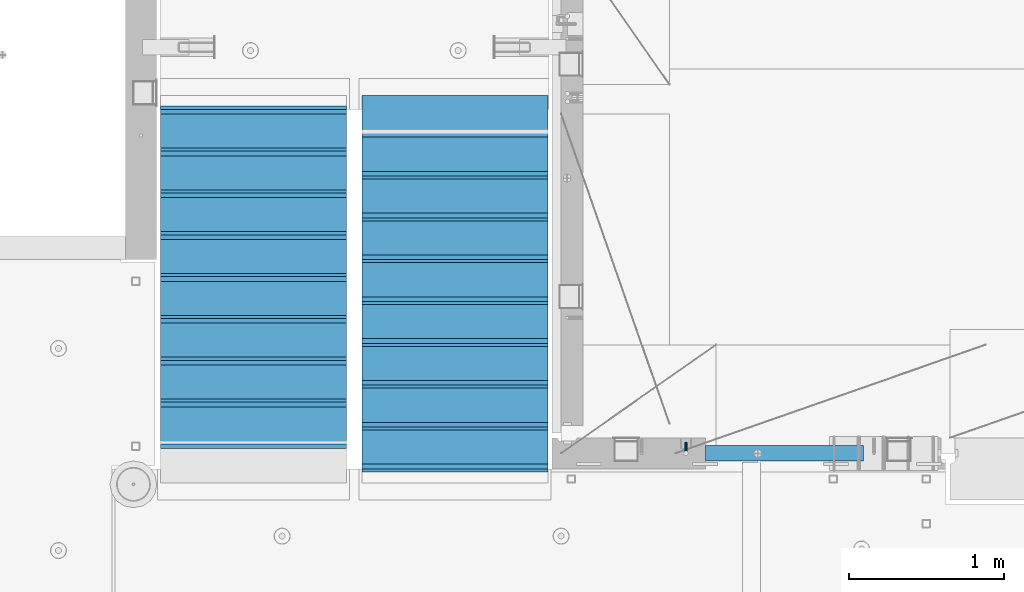
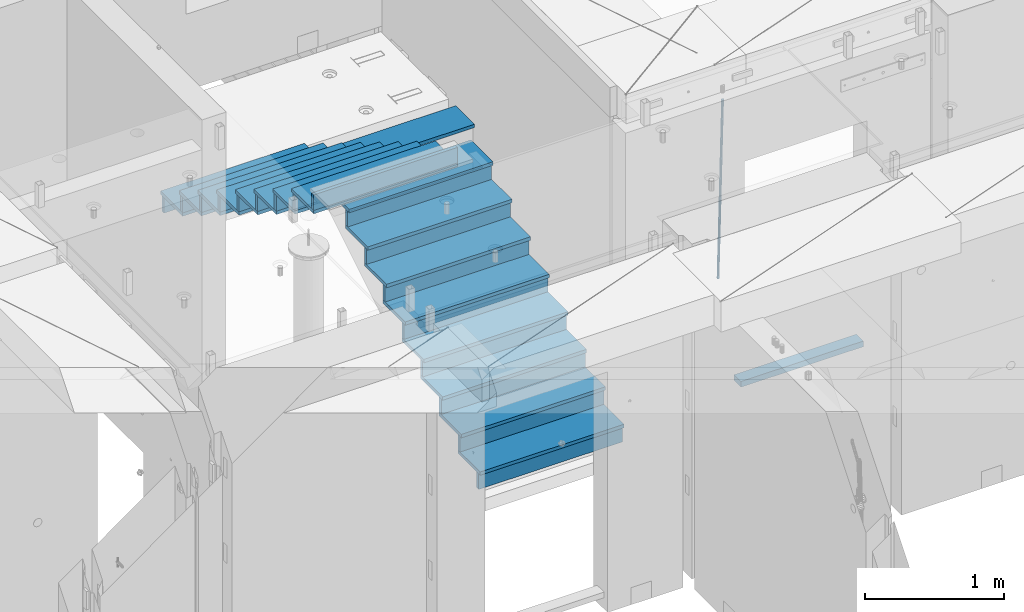
# One storey, part 119 of 349: 36 beams, 3 elements without a shape of their own.
"""IFC2X3 building model written with IfcOpenShell, lengths in millimetres."""

from ifc_helpers import new_model, si_unit, frame, origin_with_axes, place, context, subcontext, project, spatial, faceted_brep, material, type_object, element, aggregate, save


model = new_model("IFC2X3")

# Units and contexts
model_context = context("Model", 3, precision=1e-05, world=origin_with_axes())
body_context = subcontext(model_context, "Body", "Model", "MODEL_VIEW")
ifc_project = project(units=[si_unit("LENGTHUNIT", "METRE", prefix="MILLI"), si_unit("AREAUNIT", "SQUARE_METRE"), si_unit("VOLUMEUNIT", "CUBIC_METRE"), si_unit("MASSUNIT", "GRAM", prefix="KILO"), si_unit("TIMEUNIT", "SECOND"), si_unit("PLANEANGLEUNIT", "RADIAN"), si_unit("SOLIDANGLEUNIT", "STERADIAN"), si_unit("THERMODYNAMICTEMPERATUREUNIT", "DEGREE_CELSIUS"), si_unit("LUMINOUSINTENSITYUNIT", "LUMEN")], contexts=[model_context])

# Site, building, storey
site_placement = place(None, origin_with_axes())
site = spatial("IfcSite", under=ifc_project, at=site_placement, CompositionType="ELEMENT")
building_placement = place(site_placement, origin_with_axes())
building = spatial("IfcBuilding", under=site, at=building_placement, CompositionType="ELEMENT")
storey_placement = place(building_placement, origin_with_axes())
storey = spatial("IfcBuildingStorey", under=building, at=storey_placement, Name="4", CompositionType="ELEMENT", Elevation=0.0)

# Assembly, beams
assembly_1_placement = place(storey_placement, origin_with_axes())
assembly_1 = element("IfcElementAssembly", 1, at=assembly_1_placement, inside=storey, AssemblyPlace="NOTDEFINED", PredefinedType="REINFORCEMENT_UNIT")
ifc_material_1 = material()
beam_type_1 = type_object("IfcBeamType", Name="D20", PredefinedType="NOTDEFINED")
beam_1_placement = place(assembly_1_placement, frame((23075.0006866416, 17045.0000022791, 91790.0), z_axis=(0.00020576299992186, -0.999642804629538, -0.0267249099901004), x_axis=(-4.30000201928125e-08, -0.0267249099948059, 0.999642825806181)))
beam_1 = element("IfcBeam", 2, at=beam_1_placement, type_object=beam_type_1, material=ifc_material_1, Name="JM20", ObjectType="D20", context=body_context, shape_type="Brep", body=[
    faceted_brep([(0.0, -10.0, 0.0), (-4.19531716033816e-08, -7.07106781186667, -7.07106781187031), (60.4266690400545, -7.0710677960451, -7.07106780570757), (60.4266690441291, -9.99999998418934, 6.15546014159918e-09), (0.0, 0.0, -10.0), (60.426669036824, 1.58106558956206e-08, -9.99999999384454), (4.196772351861e-08, 7.07106781186303, -7.07106781186667), (60.4266690363438, 7.07106782768096, -7.07106780570757), (0.0, 10.0, 0.0), (60.4266690388904, 10.0000000158179, 6.15182216279209e-09), (4.196772351861e-08, 7.07106781185939, 7.07106781185939), (60.4266690429649, 7.07106782768096, 7.07106781802577), (0.0, 0.0, 10.0), (60.4266690461809, 1.58179318532348e-08, 10.0000000061555), (-4.19531716033816e-08, -7.07106781187031, 7.07106781185939), (60.4266690466611, -7.07106779605238, 7.07106781802213), (61.0378400410118, -7.07106779588503, -7.07106780564936), (60.991799419251, -9.99999998403655, 6.21366780251265e-09), (61.0569027789461, 1.5985278878361e-08, -9.99999999378269), (61.0378209396877, 7.07106782784831, -7.07106780564936), (60.9917724058905, 10.0000000159635, 6.21366780251265e-09), (60.9457317841297, 7.07106782781193, 7.0710678180767), (60.9266690461809, 1.59488990902901e-08, 10.0000000062028), (60.9457508854539, -7.07106779591413, 7.0710678180767), (61.6489592143771, -7.07106614513759, -7.06310863441468), (61.5568818710308, -9.9999984576425, 0.00735959856683621), (61.6870830769039, 1.71821739058942e-06, -9.99179257185824), (61.6489210170112, 7.07106947854481, -7.06310888312146), (61.556827851804, 10.0000015422847, 0.00735924683976918), (61.4647505084577, 7.07106922979438, 7.07782747982128), (61.4266266459163, 1.36643211590126e-06, 10.0065114172685), (61.464788705809, -7.07106639389531, 7.07782772852806), (176.543135720174, -7.07075579406956, -5.56673531796696), (176.451058376813, -9.99968810657447, 1.50373291501455), (176.581259582701, 0.000312069292704109, -8.49541925541052), (176.543097522794, 7.07137982961285, -5.56673556667374), (176.451004357587, 10.00031189336, 1.50373256329476), (176.35892701424, 7.07137958085514, 8.57420079627263), (176.320803151699, 0.000311717507429421, 11.5028847337162), (176.358965211621, -7.07075604281999, 8.57420104497578), (177.098753836006, -7.07075429323595, -5.55949898843028), (176.98362511232, -9.99968666800123, 1.510669025065), (177.146421932586, 0.000313595905026887, -8.48805862247536), (177.098706077581, 7.07138133041735, -5.55949936166144), (176.983557571715, 10.0003133318824, 1.51066849724157), (176.868428848029, 7.07138095712435, 8.58083651073321), (176.820760751449, 0.000313067976094317, 11.5093961447819), (176.868476606425, -7.07075466652896, 8.58083688396073), (177.654312950661, -7.07075204110879, -5.54863964998367), (177.516135294456, -9.99968450931192, 1.52107783331303), (177.711524267797, 0.000315886711177882, -8.47701274570863), (177.654255632195, 7.07138358250813, -5.54864021007961), (177.516054233929, 10.0003154905207, 1.5210770412159), (177.377876577739, 7.0713830223176, 8.59079452451624), (177.320665260588, 0.000315094497636892, 11.5191676202448), (177.377933896176, -7.07075260129932, 8.59079508461218), (299.580241614967, -7.07025777803938, -3.16539205229128), (299.442063958748, -9.99919024624614, 3.90432543100542), (299.637452932104, 0.000810149780591019, -6.09376514801625), (299.58018429653, 7.07187784557391, -3.16539261238358), (299.441982898265, 10.0008097535901, 3.90432463891557), (299.303805242045, 7.07187728538338, 10.974042122205), (299.246593924894, 0.00080935756341205, 13.9024152179336), (299.303862560482, -7.07025833822991, 10.9740426822973), (300.088882651282, -7.07025571611666, -3.15544980669438), (299.971788958996, -9.99918809853989, 3.91467979818117), (300.137357441272, 0.000812176291219657, -6.0839936725497), (300.088834180511, 7.07187990754028, -3.15545019384081), (299.971753863239, 10.0008119014747, 3.91467990454839), (299.854660170953, 7.07187951844026, 10.9848095094276), (299.806185380992, 0.000811626032373169, 13.9133533752902), (299.854708641738, -7.07025610520941, 10.9848098965813), (300.597573977022, -7.07025429077839, -3.14854421417112), (300.501599787152, -9.99918661431002, 3.92187219230618), (300.637311376035, 0.00081357714952901, -6.07720669196715), (300.597534354776, 7.07188133290401, -3.14854448120241), (300.501543752835, 10.0008133856099, 3.92187181466215), (300.40556956298, 7.07188106207104, 10.9922882211395), (300.365832163967, 0.000813194146758178, 13.9209506989318), (300.405609185211, -7.07025456160045, 10.9922884881707), (1494.60304651056, -7.06690872122999, 13.060333041718), (1494.50707232069, -9.99584104476162, 20.1307494481916), (1494.64278390956, 0.00415914670156781, 10.1316705639183), (1494.6030068883, 7.07522690244878, 13.0603327746867), (1494.50701628637, 10.004158955162, 20.1307490705476), (1494.4110420965, 7.07522663162308, 27.2011654770249), (1494.3713046975, 0.00415876370243495, 30.1298279548209), (1494.41108171875, -7.06690899205205, 27.2011657440526), (1495.1211563645, -7.06690726950183, 13.067366492749), (1495.00702625545, -9.99583964390331, 20.1375364287742), (1495.20660775043, 0.00416072652296862, 10.1393245920117), (1495.21332415029, 7.07522861253892, 13.0686179608165), (1495.13737118813, 10.0041607213934, 20.1393062718889), (1495.02324107911, 7.07522834699193, 27.2094762079141), (1494.93778969315, 0.00416035097441636, 30.1375181086514), (1494.93107329329, -7.06690753504881, 27.2082247398503), (1495.63922435709, -7.07365070849846, 13.0742491942874), (1495.5069397148, -10.00235861486, 20.1441724282631), (1495.77038591086, -0.00317370150150964, 10.1468279224828), (1495.82359171678, 7.06728286786529, 13.0767522910828), (1495.76767453534, 9.99594143344802, 20.1477123416917), (1495.63538989302, 7.0672335270865, 27.2176355756565), (1495.50422833927, -0.00324347991045215, 30.1450568474684), (1495.45102253335, -7.07370004928453, 27.2151324788683), (1517.48046966468, -7.35846502584536, 13.3649345949125), (1517.34818502239, -10.2871729322142, 20.4348578288809), (1517.61163121845, -0.287988018848409, 10.4375133231042), (1517.66483702436, 6.78246855052203, 13.3674376917079), (1517.60891984291, 9.71112711610476, 20.4383977423167), (1517.47663520063, 6.78241920973232, 27.5083209762815), (1517.34547364687, -0.288057797257352, 30.4357422480862), (1517.29226784095, -7.35851436663143, 27.5058178794898), (1518.11590717161, -7.36675126123009, 13.3733916404526), (1518.00827439407, -10.295780632965, 20.4436429663911), (1518.18994308249, -0.295529324139352, 10.4452100827657), (1518.18701289421, 6.77565927010801, 13.3743873367348), (1518.10883307132, 9.70460814510079, 20.4450510935785), (1518.00120029377, 6.77557877335857, 27.515302419517), (1517.9271643829, -0.295643163732166, 30.4434839772002), (1517.93009457119, -7.36683175797953, 27.5143067232275), (1518.75139849893, -7.36487536471395, 13.3816537936873), (1518.66841952164, -10.2938120781764, 20.4522328350286), (1518.76830418318, -0.293831718903675, 10.452712053142), (1518.7092334538, 6.77719739167878, 13.3811419616068), (1518.60878914295, 9.7060990139762, 20.4515089951637), (1518.52581016565, 6.77716230052101, 27.522088036505), (1518.50890448141, -0.293881345296541, 30.4510297770539), (1518.56797521077, -7.36491045587172, 27.5225998685855), (1618.77218426704, -7.06661321754655, 14.6790318180938), (1618.68920528975, -9.99554993101265, 21.7496108594387), (1618.78908995127, 0.0044304282637313, 11.7500900775485), (1618.73001922191, 7.07545953884255, 14.6785199860096), (1618.62957491104, 10.0043611611436, 21.748887019563), (1618.54659593375, 7.07542444768478, 28.8194660609042), (1618.52969024952, 0.00438080187086598, 31.7484078014531), (1618.58876097888, -7.06664830870795, 28.819977892992)], [[[0, 1, 2, 3]], [[1, 4, 5, 2]], [[4, 6, 7, 5]], [[6, 8, 9, 7]], [[8, 10, 11, 9]], [[10, 12, 13, 11]], [[12, 14, 15, 13]], [[14, 0, 3, 15]], [[14, 12, 10, 8, 6, 4, 1, 0]], [[3, 2, 16, 17]], [[2, 5, 18, 16]], [[5, 7, 19, 18]], [[7, 9, 20, 19]], [[9, 11, 21, 20]], [[11, 13, 22, 21]], [[13, 15, 23, 22]], [[15, 3, 17, 23]], [[17, 16, 24, 25]], [[16, 18, 26, 24]], [[18, 19, 27, 26]], [[19, 20, 28, 27]], [[20, 21, 29, 28]], [[21, 22, 30, 29]], [[22, 23, 31, 30]], [[23, 17, 25, 31]], [[25, 24, 32, 33]], [[24, 26, 34, 32]], [[26, 27, 35, 34]], [[27, 28, 36, 35]], [[28, 29, 37, 36]], [[29, 30, 38, 37]], [[30, 31, 39, 38]], [[31, 25, 33, 39]], [[33, 32, 40, 41]], [[32, 34, 42, 40]], [[34, 35, 43, 42]], [[35, 36, 44, 43]], [[36, 37, 45, 44]], [[37, 38, 46, 45]], [[38, 39, 47, 46]], [[39, 33, 41, 47]], [[41, 40, 48, 49]], [[40, 42, 50, 48]], [[42, 43, 51, 50]], [[43, 44, 52, 51]], [[44, 45, 53, 52]], [[45, 46, 54, 53]], [[46, 47, 55, 54]], [[47, 41, 49, 55]], [[49, 48, 56, 57]], [[48, 50, 58, 56]], [[50, 51, 59, 58]], [[51, 52, 60, 59]], [[52, 53, 61, 60]], [[53, 54, 62, 61]], [[54, 55, 63, 62]], [[55, 49, 57, 63]], [[57, 56, 64, 65]], [[56, 58, 66, 64]], [[58, 59, 67, 66]], [[59, 60, 68, 67]], [[60, 61, 69, 68]], [[61, 62, 70, 69]], [[62, 63, 71, 70]], [[63, 57, 65, 71]], [[65, 64, 72, 73]], [[64, 66, 74, 72]], [[66, 67, 75, 74]], [[67, 68, 76, 75]], [[68, 69, 77, 76]], [[69, 70, 78, 77]], [[70, 71, 79, 78]], [[71, 65, 73, 79]], [[73, 72, 80, 81]], [[72, 74, 82, 80]], [[74, 75, 83, 82]], [[75, 76, 84, 83]], [[76, 77, 85, 84]], [[77, 78, 86, 85]], [[78, 79, 87, 86]], [[79, 73, 81, 87]], [[81, 80, 88, 89]], [[80, 82, 90, 88]], [[82, 83, 91, 90]], [[83, 84, 92, 91]], [[84, 85, 93, 92]], [[85, 86, 94, 93]], [[86, 87, 95, 94]], [[87, 81, 89, 95]], [[89, 88, 96, 97]], [[88, 90, 98, 96]], [[90, 91, 99, 98]], [[91, 92, 100, 99]], [[92, 93, 101, 100]], [[93, 94, 102, 101]], [[94, 95, 103, 102]], [[95, 89, 97, 103]], [[97, 96, 104, 105]], [[96, 98, 106, 104]], [[98, 99, 107, 106]], [[99, 100, 108, 107]], [[100, 101, 109, 108]], [[101, 102, 110, 109]], [[102, 103, 111, 110]], [[103, 97, 105, 111]], [[105, 104, 112, 113]], [[104, 106, 114, 112]], [[106, 107, 115, 114]], [[107, 108, 116, 115]], [[108, 109, 117, 116]], [[109, 110, 118, 117]], [[110, 111, 119, 118]], [[111, 105, 113, 119]], [[113, 112, 120, 121]], [[112, 114, 122, 120]], [[114, 115, 123, 122]], [[115, 116, 124, 123]], [[116, 117, 125, 124]], [[117, 118, 126, 125]], [[118, 119, 127, 126]], [[119, 113, 121, 127]], [[121, 120, 128, 129]], [[120, 122, 130, 128]], [[122, 123, 131, 130]], [[123, 124, 132, 131]], [[124, 125, 133, 132]], [[125, 126, 134, 133]], [[126, 127, 135, 134]], [[127, 121, 129, 135]], [[130, 131, 132, 133, 134, 135, 129, 128]]]),
])
ifc_material_2 = material(Name="TIMBER/T24")
beam_type_2 = type_object("IfcBeamType", PredefinedType="NOTDEFINED")
beam_2_placement = place(assembly_1_placement, frame((23200.0006866455, 16980.0, 90880.0), z_axis=(0.0, 0.0, 1.0), x_axis=(1.0, 0.0, 0.0)))
beam_2 = element("IfcBeam", 3, at=beam_2_placement, type_object=beam_type_2, material=ifc_material_2, context=body_context, shape_type="Brep", body=[
    faceted_brep([(0.0, 50.0, -25.0), (0.0, 50.0, 25.0), (1020.0, 50.0, 25.0), (1020.0, 50.0, -25.0), (0.0, -50.0, 25.0), (1020.0, -50.0, 25.0), (0.0, -50.0, -25.0), (1020.0, -50.0, -25.0)], [[[0, 1, 2, 3]], [[1, 4, 5, 2]], [[4, 6, 7, 5]], [[6, 0, 3, 7]], [[5, 7, 3, 2]], [[6, 4, 1, 0]]]),
])
aggregate(assembly_1, [beam_1, beam_2])

assembly_2_placement = place(storey_placement, origin_with_axes())
assembly_2 = element("IfcElementAssembly", 4, at=assembly_2_placement, inside=storey, Name="E9", AssemblyPlace="NOTDEFINED", PredefinedType="NOTDEFINED")
ifc_material_3 = material(Name="Undefined/C32/40")
beam_type_3 = type_object("IfcBeamType", PredefinedType="NOTDEFINED")
beam_3_placement = place(assembly_2_placement, frame((20885.0002457424, 17024.9998138874, 93662.1), z_axis=(0.0, 1.0, 0.0), x_axis=(-1.0, 3.00000001838171e-08, 0.0)))
beam_3 = element("IfcBeam", 5, at=beam_3_placement, type_object=beam_type_3, material=ifc_material_3, Name="E9", context=body_context, shape_type="Brep", body=[
    faceted_brep([(0.0, 68.5, -15.0), (0.0, 68.5, 15.0), (1200.0, 68.5, 15.0), (1200.0, 68.5, -15.0), (0.0, -68.5, 15.0), (1200.0, -68.5, 15.0), (0.0, -68.5, -15.0), (1200.0, -68.5, -15.0)], [[[0, 1, 2, 3]], [[1, 4, 5, 2]], [[4, 6, 7, 5]], [[6, 0, 3, 7]], [[5, 7, 3, 2]], [[6, 4, 1, 0]]]),
])
beam_4_placement = place(assembly_2_placement, frame((20885.0002457424, 17294.9998138874, 93495.4), z_axis=(0.0, 1.0, 0.0), x_axis=(-1.0, 3.00000001838171e-08, 0.0)))
beam_4 = element("IfcBeam", 6, at=beam_4_placement, type_object=beam_type_3, material=ifc_material_3, Name="E9", context=body_context, shape_type="Brep", body=[
    faceted_brep([(0.0, 68.5, -15.0), (0.0, 68.5, 15.0), (1200.0, 68.5, 15.0), (1200.0, 68.5, -15.0), (0.0, -68.5, 15.0), (1200.0, -68.5, 15.0), (0.0, -68.5, -15.0), (1200.0, -68.5, -15.0)], [[[0, 1, 2, 3]], [[1, 4, 5, 2]], [[4, 6, 7, 5]], [[6, 0, 3, 7]], [[5, 7, 3, 2]], [[6, 4, 1, 0]]]),
])
beam_5_placement = place(assembly_2_placement, frame((20885.0002457424, 17564.9998138874, 93328.7), z_axis=(0.0, 1.0, 0.0), x_axis=(-1.0, 3.00000001838171e-08, 0.0)))
beam_5 = element("IfcBeam", 7, at=beam_5_placement, type_object=beam_type_3, material=ifc_material_3, Name="E9", context=body_context, shape_type="Brep", body=[
    faceted_brep([(0.0, 68.5, -15.0), (0.0, 68.5, 15.0), (1200.0, 68.5, 15.0), (1200.0, 68.5, -15.0), (0.0, -68.5, 15.0), (1200.0, -68.5, 15.0), (0.0, -68.5, -15.0), (1200.0, -68.5, -15.0)], [[[0, 1, 2, 3]], [[1, 4, 5, 2]], [[4, 6, 7, 5]], [[6, 0, 3, 7]], [[5, 7, 3, 2]], [[6, 4, 1, 0]]]),
])
beam_6_placement = place(assembly_2_placement, frame((20885.0002457424, 17834.9998138874, 93162.0), z_axis=(0.0, 1.0, 0.0), x_axis=(-1.0, 3.00000001838171e-08, 0.0)))
beam_6 = element("IfcBeam", 8, at=beam_6_placement, type_object=beam_type_3, material=ifc_material_3, Name="E9", context=body_context, shape_type="Brep", body=[
    faceted_brep([(0.0, 68.5, -15.0), (0.0, 68.5, 15.0), (1200.0, 68.5, 15.0), (1200.0, 68.5, -15.0), (0.0, -68.5, 15.0), (1200.0, -68.5, 15.0), (0.0, -68.5, -15.0), (1200.0, -68.5, -15.0)], [[[0, 1, 2, 3]], [[1, 4, 5, 2]], [[4, 6, 7, 5]], [[6, 0, 3, 7]], [[5, 7, 3, 2]], [[6, 4, 1, 0]]]),
])
beam_7_placement = place(assembly_2_placement, frame((20885.0002457424, 18104.9998138874, 92995.3), z_axis=(0.0, 1.0, 0.0), x_axis=(-1.0, 3.00000001838171e-08, 0.0)))
beam_7 = element("IfcBeam", 9, at=beam_7_placement, type_object=beam_type_3, material=ifc_material_3, Name="E9", context=body_context, shape_type="Brep", body=[
    faceted_brep([(0.0, 68.5, -15.0), (0.0, 68.5, 15.0), (1200.0, 68.5, 15.0), (1200.0, 68.5, -15.0), (0.0, -68.5, 15.0), (1200.0, -68.5, 15.0), (0.0, -68.5, -15.0), (1200.0, -68.5, -15.0)], [[[0, 1, 2, 3]], [[1, 4, 5, 2]], [[4, 6, 7, 5]], [[6, 0, 3, 7]], [[5, 7, 3, 2]], [[6, 4, 1, 0]]]),
])
beam_8_placement = place(assembly_2_placement, frame((20885.0002457424, 18374.9998138874, 92828.6), z_axis=(0.0, 1.0, 0.0), x_axis=(-1.0, 3.00000001838171e-08, 0.0)))
beam_8 = element("IfcBeam", 10, at=beam_8_placement, type_object=beam_type_3, material=ifc_material_3, Name="E9", context=body_context, shape_type="Brep", body=[
    faceted_brep([(0.0, 68.5, -15.0), (0.0, 68.5, 15.0), (1200.0, 68.5, 15.0), (1200.0, 68.5, -15.0), (0.0, -68.5, 15.0), (1200.0, -68.5, 15.0), (0.0, -68.5, -15.0), (1200.0, -68.5, -15.0)], [[[0, 1, 2, 3]], [[1, 4, 5, 2]], [[4, 6, 7, 5]], [[6, 0, 3, 7]], [[5, 7, 3, 2]], [[6, 4, 1, 0]]]),
])
beam_9_placement = place(assembly_2_placement, frame((20885.0002457424, 18644.9998138874, 92661.9), z_axis=(0.0, 1.0, 0.0), x_axis=(-1.0, 3.00000001838171e-08, 0.0)))
beam_9 = element("IfcBeam", 11, at=beam_9_placement, type_object=beam_type_3, material=ifc_material_3, Name="E9", context=body_context, shape_type="Brep", body=[
    faceted_brep([(0.0, 68.5, -15.0), (0.0, 68.5, 15.0), (1200.0, 68.5, 15.0), (1200.0, 68.5, -15.0), (0.0, -68.5, 15.0), (1200.0, -68.5, 15.0), (0.0, -68.5, -15.0), (1200.0, -68.5, -15.0)], [[[0, 1, 2, 3]], [[1, 4, 5, 2]], [[4, 6, 7, 5]], [[6, 0, 3, 7]], [[5, 7, 3, 2]], [[6, 4, 1, 0]]]),
])
beam_10_placement = place(assembly_2_placement, frame((20885.0002457424, 18914.9998138874, 92495.2), z_axis=(0.0, 1.0, 0.0), x_axis=(-1.0, 3.00000001838171e-08, 0.0)))
beam_10 = element("IfcBeam", 12, at=beam_10_placement, type_object=beam_type_3, material=ifc_material_3, Name="E9", context=body_context, shape_type="Brep", body=[
    faceted_brep([(0.0, 68.5, -15.0), (0.0, 68.5, 15.0), (1200.0, 68.5, 15.0), (1200.0, 68.5, -15.0), (0.0, -68.5, 15.0), (1200.0, -68.5, 15.0), (0.0, -68.5, -15.0), (1200.0, -68.5, -15.0)], [[[0, 1, 2, 3]], [[1, 4, 5, 2]], [[4, 6, 7, 5]], [[6, 0, 3, 7]], [[5, 7, 3, 2]], [[6, 4, 1, 0]]]),
])
beam_11_placement = place(assembly_2_placement, frame((20885.0002457424, 19184.9998138874, 92328.5), z_axis=(0.0, 1.0, 0.0), x_axis=(-1.0, 3.00000001838171e-08, 0.0)))
beam_11 = element("IfcBeam", 13, at=beam_11_placement, type_object=beam_type_3, material=ifc_material_3, Name="E9", context=body_context, shape_type="Brep", body=[
    faceted_brep([(0.0, 68.5, -15.0), (0.0, 68.5, 15.0), (1200.0, 68.5, 15.0), (1200.0, 68.5, -15.0), (0.0, -68.5, 15.0), (1200.0, -68.5, 15.0), (0.0, -68.5, -15.0), (1200.0, -68.5, -15.0)], [[[0, 1, 2, 3]], [[1, 4, 5, 2]], [[4, 6, 7, 5]], [[6, 0, 3, 7]], [[5, 7, 3, 2]], [[6, 4, 1, 0]]]),
])

assembly_3_placement = place(storey_placement, origin_with_axes())
assembly_3 = element("IfcElementAssembly", 14, at=assembly_3_placement, inside=storey, Name="E9", AssemblyPlace="NOTDEFINED", PredefinedType="NOTDEFINED")
beam_12_placement = place(assembly_3_placement, frame((20985.002175553, 18785.001025346, 91995.1036072969), z_axis=(0.0, -1.0, 0.0), x_axis=(1.0, 0.0, 0.0)))
beam_12 = element("IfcBeam", 15, at=beam_12_placement, type_object=beam_type_3, material=ifc_material_3, Name="E9", context=body_context, shape_type="Brep", body=[
    faceted_brep([(0.0, 68.5, -15.0), (0.0, 68.5, 15.0), (1200.0, 68.5, 15.0), (1200.0, 68.5, -15.0), (0.0, -68.5, 15.0), (1200.0, -68.5, 15.0), (0.0, -68.5, -15.0), (1200.0, -68.5, -15.0)], [[[0, 1, 2, 3]], [[1, 4, 5, 2]], [[4, 6, 7, 5]], [[6, 0, 3, 7]], [[5, 7, 3, 2]], [[6, 4, 1, 0]]]),
])
beam_13_placement = place(assembly_3_placement, frame((20985.002175553, 18515.001025346, 91828.4036072969), z_axis=(0.0, -1.0, 0.0), x_axis=(1.0, 0.0, 0.0)))
beam_13 = element("IfcBeam", 16, at=beam_13_placement, type_object=beam_type_3, material=ifc_material_3, Name="E9", context=body_context, shape_type="Brep", body=[
    faceted_brep([(0.0, 68.5, -15.0), (0.0, 68.5, 15.0), (1200.0, 68.5, 15.0), (1200.0, 68.5, -15.0), (0.0, -68.5, 15.0), (1200.0, -68.5, 15.0), (0.0, -68.5, -15.0), (1200.0, -68.5, -15.0)], [[[0, 1, 2, 3]], [[1, 4, 5, 2]], [[4, 6, 7, 5]], [[6, 0, 3, 7]], [[5, 7, 3, 2]], [[6, 4, 1, 0]]]),
])
beam_14_placement = place(assembly_3_placement, frame((20985.002175553, 18245.001025346, 91661.7036072969), z_axis=(0.0, -1.0, 0.0), x_axis=(1.0, 0.0, 0.0)))
beam_14 = element("IfcBeam", 17, at=beam_14_placement, type_object=beam_type_3, material=ifc_material_3, Name="E9", context=body_context, shape_type="Brep", body=[
    faceted_brep([(0.0, 68.5, -15.0), (0.0, 68.5, 15.0), (1200.0, 68.5, 15.0), (1200.0, 68.5, -15.0), (0.0, -68.5, 15.0), (1200.0, -68.5, 15.0), (0.0, -68.5, -15.0), (1200.0, -68.5, -15.0)], [[[0, 1, 2, 3]], [[1, 4, 5, 2]], [[4, 6, 7, 5]], [[6, 0, 3, 7]], [[5, 7, 3, 2]], [[6, 4, 1, 0]]]),
])
beam_15_placement = place(assembly_3_placement, frame((20985.002175553, 17975.001025346, 91495.0036072969), z_axis=(0.0, -1.0, 0.0), x_axis=(1.0, 0.0, 0.0)))
beam_15 = element("IfcBeam", 18, at=beam_15_placement, type_object=beam_type_3, material=ifc_material_3, Name="E9", context=body_context, shape_type="Brep", body=[
    faceted_brep([(0.0, 68.5, -15.0), (0.0, 68.5, 15.0), (1200.0, 68.5, 15.0), (1200.0, 68.5, -15.0), (0.0, -68.5, 15.0), (1200.0, -68.5, 15.0), (0.0, -68.5, -15.0), (1200.0, -68.5, -15.0)], [[[0, 1, 2, 3]], [[1, 4, 5, 2]], [[4, 6, 7, 5]], [[6, 0, 3, 7]], [[5, 7, 3, 2]], [[6, 4, 1, 0]]]),
])
beam_16_placement = place(assembly_3_placement, frame((20985.002175553, 17705.001025346, 91328.3036072969), z_axis=(0.0, -1.0, 0.0), x_axis=(1.0, 0.0, 0.0)))
beam_16 = element("IfcBeam", 19, at=beam_16_placement, type_object=beam_type_3, material=ifc_material_3, Name="E9", context=body_context, shape_type="Brep", body=[
    faceted_brep([(0.0, 68.5, -15.0), (0.0, 68.5, 15.0), (1200.0, 68.5, 15.0), (1200.0, 68.5, -15.0), (0.0, -68.5, 15.0), (1200.0, -68.5, 15.0), (0.0, -68.5, -15.0), (1200.0, -68.5, -15.0)], [[[0, 1, 2, 3]], [[1, 4, 5, 2]], [[4, 6, 7, 5]], [[6, 0, 3, 7]], [[5, 7, 3, 2]], [[6, 4, 1, 0]]]),
])
beam_17_placement = place(assembly_3_placement, frame((20985.002175553, 17435.001025346, 91161.6036072969), z_axis=(0.0, -1.0, 0.0), x_axis=(1.0, 0.0, 0.0)))
beam_17 = element("IfcBeam", 20, at=beam_17_placement, type_object=beam_type_3, material=ifc_material_3, Name="E9", context=body_context, shape_type="Brep", body=[
    faceted_brep([(0.0, 68.5, -15.0), (0.0, 68.5, 15.0), (1200.0, 68.5, 15.0), (1200.0, 68.5, -15.0), (0.0, -68.5, 15.0), (1200.0, -68.5, 15.0), (0.0, -68.5, -15.0), (1200.0, -68.5, -15.0)], [[[0, 1, 2, 3]], [[1, 4, 5, 2]], [[4, 6, 7, 5]], [[6, 0, 3, 7]], [[5, 7, 3, 2]], [[6, 4, 1, 0]]]),
])
beam_18_placement = place(assembly_3_placement, frame((20985.002175553, 17165.001025346, 90994.9036072969), z_axis=(0.0, -1.0, 0.0), x_axis=(1.0, 0.0, 0.0)))
beam_18 = element("IfcBeam", 21, at=beam_18_placement, type_object=beam_type_3, material=ifc_material_3, Name="E9", context=body_context, shape_type="Brep", body=[
    faceted_brep([(0.0, 68.5, -15.0), (0.0, 68.5, 15.0), (1200.0, 68.5, 15.0), (1200.0, 68.5, -15.0), (0.0, -68.5, 15.0), (1200.0, -68.5, 15.0), (0.0, -68.5, -15.0), (1200.0, -68.5, -15.0)], [[[0, 1, 2, 3]], [[1, 4, 5, 2]], [[4, 6, 7, 5]], [[6, 0, 3, 7]], [[5, 7, 3, 2]], [[6, 4, 1, 0]]]),
])
beam_19_placement = place(assembly_3_placement, frame((20985.002175553, 16895.001025346, 90828.2036072969), z_axis=(0.0, -1.0, 0.0), x_axis=(1.0, 0.0, 0.0)))
beam_19 = element("IfcBeam", 22, at=beam_19_placement, type_object=beam_type_3, material=ifc_material_3, Name="E9", context=body_context, shape_type="Brep", body=[
    faceted_brep([(0.0, 68.5, -15.0), (0.0, 68.5, 15.0), (1200.0, 68.5, 15.0), (1200.0, 68.5, -15.0), (0.0, -68.5, 15.0), (1200.0, -68.5, 15.0), (0.0, -68.5, -15.0), (1200.0, -68.5, -15.0)], [[[0, 1, 2, 3]], [[1, 4, 5, 2]], [[4, 6, 7, 5]], [[6, 0, 3, 7]], [[5, 7, 3, 2]], [[6, 4, 1, 0]]]),
])

# Beam
beam_type_4 = type_object("IfcBeamType", PredefinedType="NOTDEFINED")
beam_20_placement = place(assembly_2_placement, frame((20885.0002457424, 17169.9998138874, 93578.6), z_axis=(0.0, 1.0, 0.0), x_axis=(-1.0, 3.00000001838171e-08, 0.0)))
beam_20 = element("IfcBeam", 23, at=beam_20_placement, type_object=beam_type_4, material=ifc_material_3, Name="E9", context=body_context, shape_type="Brep", body=[
    faceted_brep([(0.0, 15.0, -160.0), (0.0, 15.0, 160.0), (1200.0, 15.0, 160.0), (1200.0, 15.0, -160.0), (0.0, -15.0, 160.0), (1200.0, -15.0, 160.0), (0.0, -15.0, -160.0), (1200.0, -15.0, -160.0)], [[[0, 1, 2, 3]], [[1, 4, 5, 2]], [[4, 6, 7, 5]], [[6, 0, 3, 7]], [[5, 7, 3, 2]], [[6, 4, 1, 0]]]),
])

beam_21_placement = place(assembly_2_placement, frame((20885.0002457424, 17439.9998138874, 93411.9), z_axis=(0.0, 1.0, 0.0), x_axis=(-1.0, 3.00000001838171e-08, 0.0)))
beam_21 = element("IfcBeam", 24, at=beam_21_placement, type_object=beam_type_4, material=ifc_material_3, Name="E9", context=body_context, shape_type="Brep", body=[
    faceted_brep([(0.0, 15.0, -160.0), (0.0, 15.0, 160.0), (1200.0, 15.0, 160.0), (1200.0, 15.0, -160.0), (0.0, -15.0, 160.0), (1200.0, -15.0, 160.0), (0.0, -15.0, -160.0), (1200.0, -15.0, -160.0)], [[[0, 1, 2, 3]], [[1, 4, 5, 2]], [[4, 6, 7, 5]], [[6, 0, 3, 7]], [[5, 7, 3, 2]], [[6, 4, 1, 0]]]),
])

beam_22_placement = place(assembly_2_placement, frame((20885.0002457424, 17709.9998138874, 93245.2), z_axis=(0.0, 1.0, 0.0), x_axis=(-1.0, 3.00000001838171e-08, 0.0)))
beam_22 = element("IfcBeam", 25, at=beam_22_placement, type_object=beam_type_4, material=ifc_material_3, Name="E9", context=body_context, shape_type="Brep", body=[
    faceted_brep([(0.0, 15.0, -160.0), (0.0, 15.0, 160.0), (1200.0, 15.0, 160.0), (1200.0, 15.0, -160.0), (0.0, -15.0, 160.0), (1200.0, -15.0, 160.0), (0.0, -15.0, -160.0), (1200.0, -15.0, -160.0)], [[[0, 1, 2, 3]], [[1, 4, 5, 2]], [[4, 6, 7, 5]], [[6, 0, 3, 7]], [[5, 7, 3, 2]], [[6, 4, 1, 0]]]),
])

beam_23_placement = place(assembly_2_placement, frame((20885.0002457424, 17979.9998138874, 93078.5), z_axis=(0.0, 1.0, 0.0), x_axis=(-1.0, 3.00000001838171e-08, 0.0)))
beam_23 = element("IfcBeam", 26, at=beam_23_placement, type_object=beam_type_4, material=ifc_material_3, Name="E9", context=body_context, shape_type="Brep", body=[
    faceted_brep([(0.0, 15.0, -160.0), (0.0, 15.0, 160.0), (1200.0, 15.0, 160.0), (1200.0, 15.0, -160.0), (0.0, -15.0, 160.0), (1200.0, -15.0, 160.0), (0.0, -15.0, -160.0), (1200.0, -15.0, -160.0)], [[[0, 1, 2, 3]], [[1, 4, 5, 2]], [[4, 6, 7, 5]], [[6, 0, 3, 7]], [[5, 7, 3, 2]], [[6, 4, 1, 0]]]),
])

beam_24_placement = place(assembly_2_placement, frame((20885.0002457424, 18249.9998138874, 92911.8), z_axis=(0.0, 1.0, 0.0), x_axis=(-1.0, 3.00000001838171e-08, 0.0)))
beam_24 = element("IfcBeam", 27, at=beam_24_placement, type_object=beam_type_4, material=ifc_material_3, Name="E9", context=body_context, shape_type="Brep", body=[
    faceted_brep([(0.0, 15.0, -160.0), (0.0, 15.0, 160.0), (1200.0, 15.0, 160.0), (1200.0, 15.0, -160.0), (0.0, -15.0, 160.0), (1200.0, -15.0, 160.0), (0.0, -15.0, -160.0), (1200.0, -15.0, -160.0)], [[[0, 1, 2, 3]], [[1, 4, 5, 2]], [[4, 6, 7, 5]], [[6, 0, 3, 7]], [[5, 7, 3, 2]], [[6, 4, 1, 0]]]),
])

beam_25_placement = place(assembly_2_placement, frame((20885.0002457424, 18519.9998138874, 92745.1), z_axis=(0.0, 1.0, 0.0), x_axis=(-1.0, 3.00000001838171e-08, 0.0)))
beam_25 = element("IfcBeam", 28, at=beam_25_placement, type_object=beam_type_4, material=ifc_material_3, Name="E9", context=body_context, shape_type="Brep", body=[
    faceted_brep([(0.0, 15.0, -160.0), (0.0, 15.0, 160.0), (1200.0, 15.0, 160.0), (1200.0, 15.0, -160.0), (0.0, -15.0, 160.0), (1200.0, -15.0, 160.0), (0.0, -15.0, -160.0), (1200.0, -15.0, -160.0)], [[[0, 1, 2, 3]], [[1, 4, 5, 2]], [[4, 6, 7, 5]], [[6, 0, 3, 7]], [[5, 7, 3, 2]], [[6, 4, 1, 0]]]),
])

beam_26_placement = place(assembly_2_placement, frame((20885.0002457424, 18789.9998138874, 92578.4), z_axis=(0.0, 1.0, 0.0), x_axis=(-1.0, 3.00000001838171e-08, 0.0)))
beam_26 = element("IfcBeam", 29, at=beam_26_placement, type_object=beam_type_4, material=ifc_material_3, Name="E9", context=body_context, shape_type="Brep", body=[
    faceted_brep([(0.0, 15.0, -160.0), (0.0, 15.0, 160.0), (1200.0, 15.0, 160.0), (1200.0, 15.0, -160.0), (0.0, -15.0, 160.0), (1200.0, -15.0, 160.0), (0.0, -15.0, -160.0), (1200.0, -15.0, -160.0)], [[[0, 1, 2, 3]], [[1, 4, 5, 2]], [[4, 6, 7, 5]], [[6, 0, 3, 7]], [[5, 7, 3, 2]], [[6, 4, 1, 0]]]),
])

beam_27_placement = place(assembly_2_placement, frame((20885.0002457424, 19059.9998138874, 92411.7), z_axis=(0.0, 1.0, 0.0), x_axis=(-1.0, 3.00000001838171e-08, 0.0)))
beam_27 = element("IfcBeam", 30, at=beam_27_placement, type_object=beam_type_4, material=ifc_material_3, Name="E9", context=body_context, shape_type="Brep", body=[
    faceted_brep([(0.0, 15.0, -160.0), (0.0, 15.0, 160.0), (1200.0, 15.0, 160.0), (1200.0, 15.0, -160.0), (0.0, -15.0, 160.0), (1200.0, -15.0, 160.0), (0.0, -15.0, -160.0), (1200.0, -15.0, -160.0)], [[[0, 1, 2, 3]], [[1, 4, 5, 2]], [[4, 6, 7, 5]], [[6, 0, 3, 7]], [[5, 7, 3, 2]], [[6, 4, 1, 0]]]),
])

aggregate(assembly_2, [beam_3, beam_20, beam_4, beam_21, beam_5, beam_22, beam_6, beam_23, beam_7, beam_24, beam_8, beam_25, beam_9, beam_26, beam_10, beam_27, beam_11])

beam_28_placement = place(assembly_3_placement, frame((20985.002175553, 18910.001025346, 92078.303607297), z_axis=(0.0, -1.0, 0.0), x_axis=(1.0, 0.0, 0.0)))
beam_28 = element("IfcBeam", 31, at=beam_28_placement, type_object=beam_type_4, material=ifc_material_3, Name="E9", context=body_context, shape_type="Brep", body=[
    faceted_brep([(0.0, 15.0, -160.0), (0.0, 15.0, 160.0), (1200.0, 15.0, 160.0), (1200.0, 15.0, -160.0), (0.0, -15.0, 160.0), (1200.0, -15.0, 160.0), (0.0, -15.0, -160.0), (1200.0, -15.0, -160.0)], [[[0, 1, 2, 3]], [[1, 4, 5, 2]], [[4, 6, 7, 5]], [[6, 0, 3, 7]], [[5, 7, 3, 2]], [[6, 4, 1, 0]]]),
])

beam_29_placement = place(assembly_3_placement, frame((20985.002175553, 18640.001025346, 91911.6036072969), z_axis=(0.0, -1.0, 0.0), x_axis=(1.0, 0.0, 0.0)))
beam_29 = element("IfcBeam", 32, at=beam_29_placement, type_object=beam_type_4, material=ifc_material_3, Name="E9", context=body_context, shape_type="Brep", body=[
    faceted_brep([(0.0, 15.0, -160.0), (0.0, 15.0, 160.0), (1200.0, 15.0, 160.0), (1200.0, 15.0, -160.0), (0.0, -15.0, 160.0), (1200.0, -15.0, 160.0), (0.0, -15.0, -160.0), (1200.0, -15.0, -160.0)], [[[0, 1, 2, 3]], [[1, 4, 5, 2]], [[4, 6, 7, 5]], [[6, 0, 3, 7]], [[5, 7, 3, 2]], [[6, 4, 1, 0]]]),
])

beam_30_placement = place(assembly_3_placement, frame((20985.002175553, 18370.001025346, 91744.9036072969), z_axis=(0.0, -1.0, 0.0), x_axis=(1.0, 0.0, 0.0)))
beam_30 = element("IfcBeam", 33, at=beam_30_placement, type_object=beam_type_4, material=ifc_material_3, Name="E9", context=body_context, shape_type="Brep", body=[
    faceted_brep([(0.0, 15.0, -160.0), (0.0, 15.0, 160.0), (1200.0, 15.0, 160.0), (1200.0, 15.0, -160.0), (0.0, -15.0, 160.0), (1200.0, -15.0, 160.0), (0.0, -15.0, -160.0), (1200.0, -15.0, -160.0)], [[[0, 1, 2, 3]], [[1, 4, 5, 2]], [[4, 6, 7, 5]], [[6, 0, 3, 7]], [[5, 7, 3, 2]], [[6, 4, 1, 0]]]),
])

beam_31_placement = place(assembly_3_placement, frame((20985.002175553, 18100.001025346, 91578.2036072969), z_axis=(0.0, -1.0, 0.0), x_axis=(1.0, 0.0, 0.0)))
beam_31 = element("IfcBeam", 34, at=beam_31_placement, type_object=beam_type_4, material=ifc_material_3, Name="E9", context=body_context, shape_type="Brep", body=[
    faceted_brep([(0.0, 15.0, -160.0), (0.0, 15.0, 160.0), (1200.0, 15.0, 160.0), (1200.0, 15.0, -160.0), (0.0, -15.0, 160.0), (1200.0, -15.0, 160.0), (0.0, -15.0, -160.0), (1200.0, -15.0, -160.0)], [[[0, 1, 2, 3]], [[1, 4, 5, 2]], [[4, 6, 7, 5]], [[6, 0, 3, 7]], [[5, 7, 3, 2]], [[6, 4, 1, 0]]]),
])

beam_32_placement = place(assembly_3_placement, frame((20985.002175553, 17830.001025346, 91411.5036072969), z_axis=(0.0, -1.0, 0.0), x_axis=(1.0, 0.0, 0.0)))
beam_32 = element("IfcBeam", 35, at=beam_32_placement, type_object=beam_type_4, material=ifc_material_3, Name="E9", context=body_context, shape_type="Brep", body=[
    faceted_brep([(0.0, 15.0, -160.0), (0.0, 15.0, 160.0), (1200.0, 15.0, 160.0), (1200.0, 15.0, -160.0), (0.0, -15.0, 160.0), (1200.0, -15.0, 160.0), (0.0, -15.0, -160.0), (1200.0, -15.0, -160.0)], [[[0, 1, 2, 3]], [[1, 4, 5, 2]], [[4, 6, 7, 5]], [[6, 0, 3, 7]], [[5, 7, 3, 2]], [[6, 4, 1, 0]]]),
])

beam_33_placement = place(assembly_3_placement, frame((20985.002175553, 17560.001025346, 91244.8036072969), z_axis=(0.0, -1.0, 0.0), x_axis=(1.0, 0.0, 0.0)))
beam_33 = element("IfcBeam", 36, at=beam_33_placement, type_object=beam_type_4, material=ifc_material_3, Name="E9", context=body_context, shape_type="Brep", body=[
    faceted_brep([(0.0, 15.0, -160.0), (0.0, 15.0, 160.0), (1200.0, 15.0, 160.0), (1200.0, 15.0, -160.0), (0.0, -15.0, 160.0), (1200.0, -15.0, 160.0), (0.0, -15.0, -160.0), (1200.0, -15.0, -160.0)], [[[0, 1, 2, 3]], [[1, 4, 5, 2]], [[4, 6, 7, 5]], [[6, 0, 3, 7]], [[5, 7, 3, 2]], [[6, 4, 1, 0]]]),
])

beam_34_placement = place(assembly_3_placement, frame((20985.002175553, 17290.001025346, 91078.1036072969), z_axis=(0.0, -1.0, 0.0), x_axis=(1.0, 0.0, 0.0)))
beam_34 = element("IfcBeam", 37, at=beam_34_placement, type_object=beam_type_4, material=ifc_material_3, Name="E9", context=body_context, shape_type="Brep", body=[
    faceted_brep([(0.0, 15.0, -160.0), (0.0, 15.0, 160.0), (1200.0, 15.0, 160.0), (1200.0, 15.0, -160.0), (0.0, -15.0, 160.0), (1200.0, -15.0, 160.0), (0.0, -15.0, -160.0), (1200.0, -15.0, -160.0)], [[[0, 1, 2, 3]], [[1, 4, 5, 2]], [[4, 6, 7, 5]], [[6, 0, 3, 7]], [[5, 7, 3, 2]], [[6, 4, 1, 0]]]),
])

beam_35_placement = place(assembly_3_placement, frame((20985.002175553, 17020.001025346, 90911.4036072969), z_axis=(0.0, -1.0, 0.0), x_axis=(1.0, 0.0, 0.0)))
beam_35 = element("IfcBeam", 38, at=beam_35_placement, type_object=beam_type_4, material=ifc_material_3, Name="E9", context=body_context, shape_type="Brep", body=[
    faceted_brep([(0.0, 15.0, -160.0), (0.0, 15.0, 160.0), (1200.0, 15.0, 160.0), (1200.0, 15.0, -160.0), (0.0, -15.0, 160.0), (1200.0, -15.0, 160.0), (0.0, -15.0, -160.0), (1200.0, -15.0, -160.0)], [[[0, 1, 2, 3]], [[1, 4, 5, 2]], [[4, 6, 7, 5]], [[6, 0, 3, 7]], [[5, 7, 3, 2]], [[6, 4, 1, 0]]]),
])

beam_type_5 = type_object("IfcBeamType", PredefinedType="NOTDEFINED")
beam_36_placement = place(assembly_3_placement, frame((20985.002175553, 19155.001025346, 92245.003607297), z_axis=(0.0, -1.0, 0.0), x_axis=(1.0, 0.0, 0.0)))
beam_36 = element("IfcBeam", 39, at=beam_36_placement, type_object=beam_type_5, material=ifc_material_3, Name="E9", context=body_context, shape_type="Brep", body=[
    faceted_brep([(0.0, 15.0, -135.0), (0.0, 15.0, 135.0), (1200.0, 15.0, 135.0), (1200.0, 15.0, -135.0), (0.0, -15.0, 135.0), (1200.0, -15.0, 135.0), (0.0, -15.0, -135.0), (1200.0, -15.0, -135.0)], [[[0, 1, 2, 3]], [[1, 4, 5, 2]], [[4, 6, 7, 5]], [[6, 0, 3, 7]], [[5, 7, 3, 2]], [[6, 4, 1, 0]]]),
])

aggregate(assembly_3, [beam_28, beam_12, beam_29, beam_13, beam_30, beam_14, beam_31, beam_15, beam_32, beam_16, beam_33, beam_17, beam_34, beam_18, beam_35, beam_36, beam_19])

save(model, "model.ifc")
